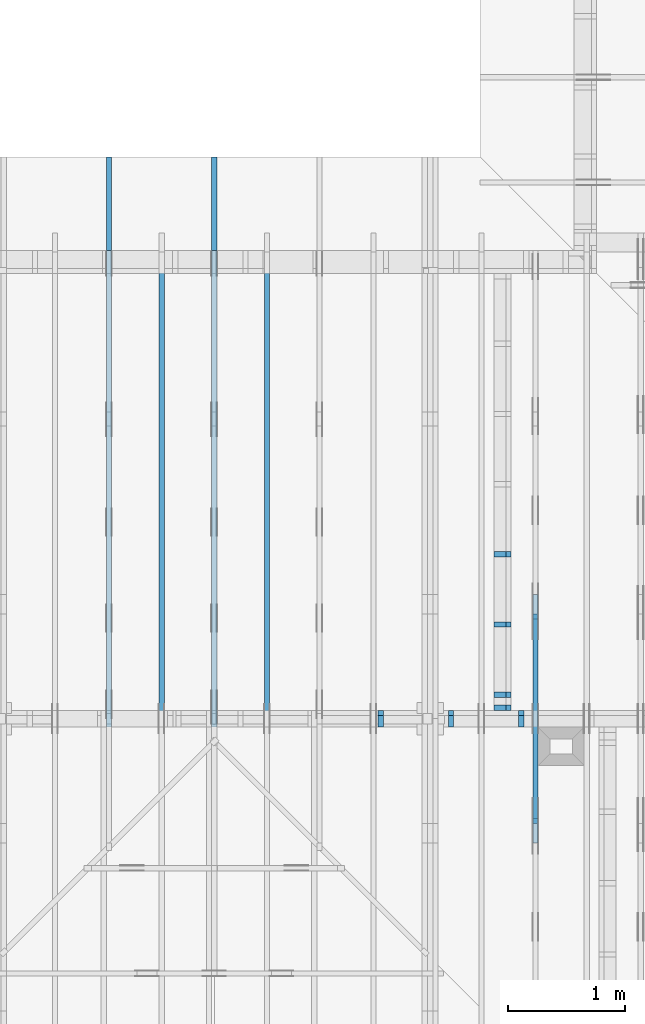
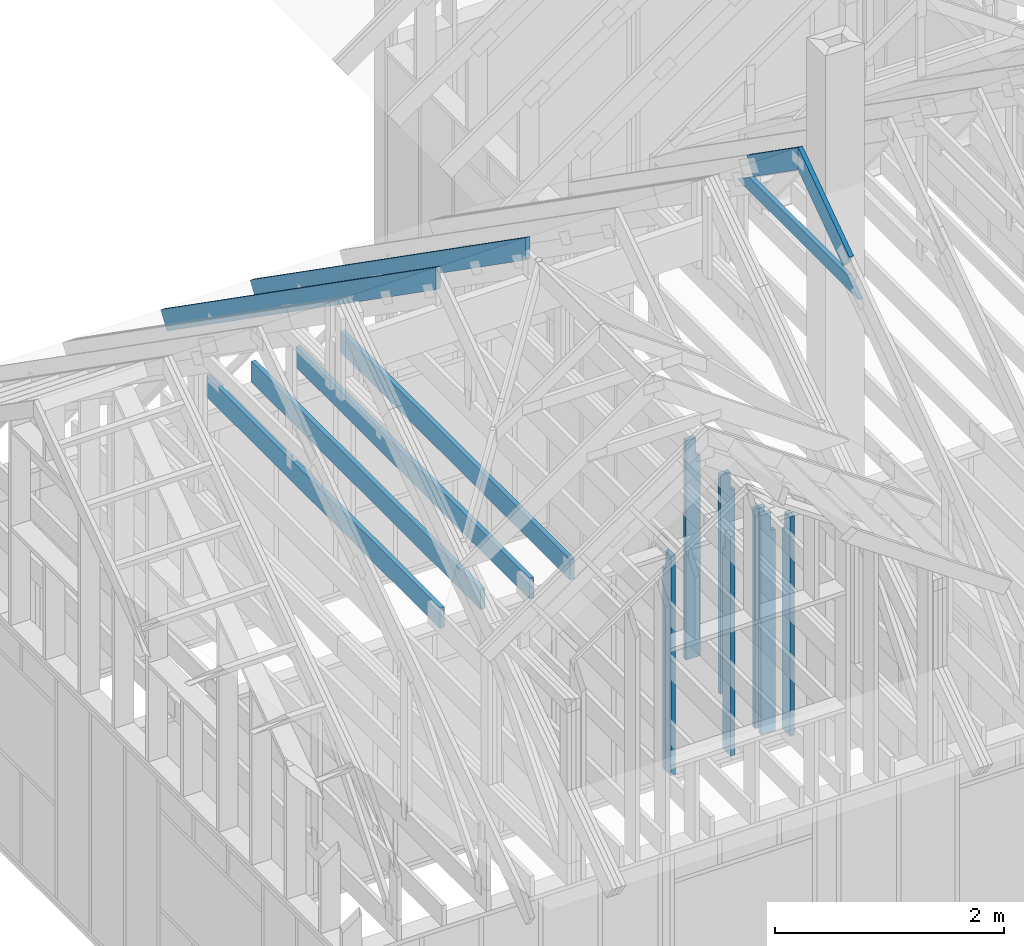
# One storey, part 16 of 70: 16 members, 7 elements without a shape of their own.
"""IFC2X3 building model written with IfcOpenShell, lengths in millimetres."""

from ifc_helpers import new_model, si_unit, frame, origin, origin_with_axes, origin_2d, place, context, project, spatial, faceted_brep, element, aggregate, save


model = new_model("IFC2X3")

# Units and contexts
model_context = context("Model", 3, precision=1e-05, world=origin())
plan_context = context("Plan", 2, precision=1e-05, world=origin_2d())
ifc_project = project(units=[si_unit("LENGTHUNIT", "METRE", prefix="MILLI"), si_unit("AREAUNIT", "SQUARE_METRE"), si_unit("VOLUMEUNIT", "CUBIC_METRE"), si_unit("SOLIDANGLEUNIT", "STERADIAN"), si_unit("PLANEANGLEUNIT", "RADIAN"), si_unit("MASSUNIT", "GRAM"), si_unit("TIMEUNIT", "SECOND"), si_unit("THERMODYNAMICTEMPERATUREUNIT", "DEGREE_CELSIUS"), si_unit("LUMINOUSINTENSITYUNIT", "LUMEN")], contexts=[model_context, plan_context])

# Site, building, storey
site_placement = place(None, origin_with_axes())
site = spatial("IfcSite", under=ifc_project, at=site_placement, CompositionType="ELEMENT")
building_placement = place(site_placement, origin_with_axes())
building = spatial("IfcBuilding", under=site, at=building_placement, Name="Layout 1", CompositionType="ELEMENT")
storey_placement = place(building_placement, origin_with_axes())
storey = spatial("IfcBuildingStorey", under=building, at=storey_placement, Name="Storey 1", CompositionType="ELEMENT", Elevation=0.0)

# Assembly, member
assembly_1_placement = place(storey_placement, frame((3455.0000000000005, 8000.000000000001, 1.3776821480501744e-15), z_axis=(-1.0, 1.836909530733566e-16, 6.123031769111886e-17), x_axis=(-1.836909530733566e-16, -1.0, 0.0)))
assembly_1 = element("IfcElementAssembly", 1, at=assembly_1_placement, inside=storey, Name="MB1", AssemblyPlace="FACTORY", PredefinedType="TRUSS")
member_1_placement = place(assembly_1_placement, frame((4000.0000000000005, 219.99999999999997, -45.0), z_axis=(0.0, 0.0, 1.0), x_axis=(-1.0, 1.2246063538223773e-16, 0.0)))
member_1 = element("IfcMember", 2, at=member_1_placement, Name="B3", context=model_context, shape_type="Brep", body=[
    faceted_brep([(4000.0000000000005, 220.00000000000045, 45.0), (0.0, 220.00000000000045, 45.0), (0.0, 0.0, 45.0), (4000.0000000000005, 0.0, 45.0), (0.0, 220.00000000000045, 0.0), (4000.0000000000005, 220.00000000000045, 4.89842541528951e-13), (4000.0000000000005, 0.0, 4.89842541528951e-13), (0.0, 0.0, 0.0), (0.0, 0.0, 0.0), (2.755364296100349e-15, -3.3742366240998092e-31, 45.0), (2.969670408019265e-14, 220.0, 45.0), (2.69413397840923e-14, 220.0, -1.6496267940043512e-30), (4000.0000000000005, -7.347638122934265e-13, 7.283414641863702e-29), (4000.0000000000005, -7.320084479973261e-13, 45.0), (5.061354936149714e-31, 2.755364296100349e-15, 45.0), (0.0, 0.0, 0.0), (4000.0000000000005, 220.00000000000045, 0.0), (4000.0000000000005, 220.00000000000045, 45.0), (4000.0000000000005, 4.547473508864641e-13, 45.0), (4000.0000000000005, 4.547473508864641e-13, 0.0), (0.0, 220.0, 0.0), (0.0, 220.0, 45.0), (4000.0000000000005, 220.00000000000065, 45.0), (4000.0000000000005, 220.00000000000065, 1.1044052673094165e-29)], [[[0, 1, 2, 3]], [[4, 5, 6, 7]], [[8, 9, 10, 11]], [[12, 13, 14, 15]], [[16, 17, 18, 19]], [[20, 21, 22, 23]]]),
])
aggregate(assembly_1, [member_1])

assembly_2_placement = place(storey_placement, frame((4355.0, 8000.0, 1.3776821480501744e-15), z_axis=(-1.0, 1.836909530733566e-16, 6.123031769111886e-17), x_axis=(-1.836909530733566e-16, -1.0, 0.0)))
assembly_2 = element("IfcElementAssembly", 3, at=assembly_2_placement, inside=storey, Name="MB1", AssemblyPlace="FACTORY", PredefinedType="TRUSS")
member_2_placement = place(assembly_2_placement, frame((4000.0000000000005, 219.99999999999997, -45.0), z_axis=(0.0, 0.0, 1.0), x_axis=(-1.0, 1.2246063538223773e-16, 0.0)))
member_2 = element("IfcMember", 4, at=member_2_placement, Name="B3", context=model_context, shape_type="Brep", body=[
    faceted_brep([(4000.0000000000005, 220.00000000000045, 45.0), (0.0, 220.00000000000045, 45.0), (0.0, 0.0, 45.0), (4000.0000000000005, 0.0, 45.0), (0.0, 220.00000000000045, 0.0), (4000.0000000000005, 220.00000000000045, 4.89842541528951e-13), (4000.0000000000005, 0.0, 4.89842541528951e-13), (0.0, 0.0, 0.0), (0.0, 0.0, 0.0), (2.755364296100349e-15, -3.3742366240998092e-31, 45.0), (2.969670408019265e-14, 220.0, 45.0), (2.69413397840923e-14, 220.0, -1.6496267940043512e-30), (4000.0000000000005, -7.347638122934265e-13, 7.283414641863702e-29), (4000.0000000000005, -7.320084479973261e-13, 45.0), (5.061354936149714e-31, 2.755364296100349e-15, 45.0), (0.0, 0.0, 0.0), (4000.0000000000005, 220.00000000000045, 0.0), (4000.0000000000005, 220.00000000000045, 45.0), (4000.0000000000005, 4.547473508864641e-13, 45.0), (4000.0000000000005, 4.547473508864641e-13, 0.0), (0.0, 220.0, 0.0), (0.0, 220.0, 45.0), (4000.0000000000005, 220.00000000000065, 45.0), (4000.0000000000005, 220.00000000000065, 1.1044052673094165e-29)], [[[0, 1, 2, 3]], [[4, 5, 6, 7]], [[8, 9, 10, 11]], [[12, 13, 14, 15]], [[16, 17, 18, 19]], [[20, 21, 22, 23]]]),
])
aggregate(assembly_2, [member_2])

# Assembly, members
assembly_3_placement = place(storey_placement, frame((-48.55339059327651, 3927.500000000001, -2470.0), z_axis=(0.0, -1.0, 6.123031769111886e-17), x_axis=(1.0, 0.0, 0.0)))
assembly_3 = element("IfcElementAssembly", 5, at=assembly_3_placement, inside=storey, Name="VE8", AssemblyPlace="FACTORY", PredefinedType="NOTDEFINED")
member_3_placement = place(assembly_3_placement, frame((5377.500000001819, 2425.0, -145.0), z_axis=(0.0, 0.0, 1.0), x_axis=(-1.836909530733566e-16, -1.0, 0.0)))
member_3 = element("IfcMember", 6, at=member_3_placement, Name="S42", context=model_context, shape_type="Brep", body=[
    faceted_brep([(0.0, 45.00000000001455, 45.0), (195.00000000186265, 45.00000000001455, 45.00000000000002), (195.00000000186265, 1.4551915228366852e-11, 45.00000000000002), (0.0, 1.4551915228366852e-11, 45.0), (195.00000000186265, 1.3642420526593924e-11, 0.0), (195.00000000186265, 1.3642420526593924e-11, 45.0), (195.00000000186265, 45.00000000001455, 45.0), (195.00000000186265, 45.00000000001455, 0.0), (2.755364296102131e-15, 1.4551915228366852e-11, 45.0), (8.878396065214018e-15, 1.4551915228366852e-11, 145.0), (1.4389124657414716e-14, 45.00000000001455, 145.0), (8.26609288830283e-15, 45.00000000001455, 45.0), (2335.0, 1.4122996852940564e-11, 2.626280839091018e-29), (2335.0, 1.4131875249005776e-11, 145.0), (1.6308810349815745e-30, 1.4560793624432064e-11, 145.0), (5.061354936149714e-31, 1.4554670592662952e-11, 45.0), (195.00000000186265, 1.4518850856813305e-11, 45.0), (195.00000000186265, 1.4516095492517205e-11, 2.193253805685862e-30), (-1.6871183120499046e-31, 45.00000000001455, 45.0), (-5.436270116605248e-31, 45.000000000014545, 145.0), (2335.0, 45.0000000000144, 145.0), (2335.0, 45.00000000001441, -8.67746995743113e-30), (195.00000000186265, 45.00000000001454, -7.888609052210118e-31), (195.00000000186265, 45.00000000001454, 45.0), (2335.0, 45.00000000001455, 2.842170943040401e-14), (2335.0, 45.00000000001455, 145.0), (2335.0, 0.0, 145.0), (2335.0, 0.0, 2.842170943040401e-14), (2335.0, 45.00000000001455, 145.0), (0.0, 45.00000000001455, 145.0), (0.0, 1.4551915228366852e-11, 145.0), (2335.0, 1.4551915228366852e-11, 145.0), (195.00000000186265, 45.00000000001455, 2.3879823899764457e-14), (2335.0, 45.00000000001455, 2.859455836175251e-13), (2335.0, 0.0, 2.859455836175251e-13), (195.00000000186265, 0.0, 2.3879823899764457e-14)], [[[0, 1, 2, 3]], [[4, 5, 6, 7]], [[8, 9, 10, 11]], [[12, 13, 14, 15, 16, 17]], [[18, 19, 20, 21, 22, 23]], [[24, 25, 26, 27]], [[28, 29, 30, 31]], [[32, 33, 34, 35]]]),
])
member_4_placement = place(assembly_3_placement, frame((5977.5000000018335, 2425.0, -145.0), z_axis=(0.0, 0.0, 1.0), x_axis=(-1.836909530733566e-16, -1.0, 0.0)))
member_4 = element("IfcMember", 7, at=member_4_placement, Name="S42", context=model_context, shape_type="Brep", body=[
    faceted_brep([(0.0, 45.00000000001455, 45.0), (195.00000000186265, 45.00000000001455, 45.00000000000002), (195.00000000186265, 0.0, 45.00000000000002), (0.0, 0.0, 45.0), (195.00000000186265, 0.0, 0.0), (195.00000000186265, -3.3742366240998092e-31, 45.0), (195.00000000186265, 45.00000000001364, 45.0), (195.00000000186265, 45.00000000001364, 0.0), (2.755364296100349e-15, -3.3742366240998092e-31, 45.0), (8.878396065212235e-15, -1.0872540233210496e-30, 145.0), (1.4389124657414716e-14, 45.00000000001455, 145.0), (8.26609288830283e-15, 45.00000000001455, 45.0), (2335.0, -4.2891837542628763e-13, 2.626280839091018e-29), (2335.0, -4.200399793610754e-13, 145.0), (1.6308810349815745e-30, 8.878396065212235e-15, 145.0), (5.061354936149714e-31, 2.755364296100349e-15, 45.0), (195.00000000186265, -3.306437155354634e-14, 45.0), (195.00000000186265, -3.5819735849646686e-14, 2.193253805685826e-30), (-1.6871183120499046e-31, 45.00000000001364, 45.0), (-5.436270116605248e-31, 45.000000000013635, 145.0), (2335.0, 45.00000000001349, 145.0), (2335.0, 45.0000000000135, -8.67746995743113e-30), (195.00000000186265, 45.00000000001363, -7.888609052210118e-31), (195.00000000186265, 45.00000000001363, 45.0), (2335.0, 45.0, 2.842170943040401e-14), (2335.0, 45.0, 145.0), (2335.0, 0.0, 145.0), (2335.0, 0.0, 0.0), (2335.0, 45.0, 145.0), (0.0, 45.0, 145.0), (0.0, 0.0, 145.0), (2335.0, 0.0, 145.0), (195.00000000186265, 45.00000000001364, 2.3879823899764457e-14), (2335.0, 45.00000000001364, 2.859455836175251e-13), (2335.0, 0.0, 2.859455836175251e-13), (195.00000000186265, 0.0, 2.3879823899764457e-14)], [[[0, 1, 2, 3]], [[4, 5, 6, 7]], [[8, 9, 10, 11]], [[12, 13, 14, 15, 16, 17]], [[18, 19, 20, 21, 22, 23]], [[24, 25, 26, 27]], [[28, 29, 30, 31]], [[32, 33, 34, 35]]]),
])
member_5_placement = place(assembly_3_placement, frame((6577.500000001819, 2425.0, -145.0), z_axis=(0.0, 0.0, 1.0), x_axis=(-1.836909530733566e-16, -1.0, 0.0)))
member_5 = element("IfcMember", 8, at=member_5_placement, Name="S42", context=model_context, shape_type="Brep", body=[
    faceted_brep([(0.0, 45.00000000001455, 45.0), (195.00000000186265, 45.00000000001455, 45.00000000000002), (195.00000000186265, 2.9103830456733704e-11, 45.00000000000002), (0.0, 2.9103830456733704e-11, 45.0), (195.00000000186265, 2.637534635141492e-11, 0.0), (195.00000000186265, 2.637534635141492e-11, 45.0), (195.00000000186265, 45.00000000001364, 45.0), (195.00000000186265, 45.00000000001364, 0.0), (2.755364296103913e-15, 2.9103830456733704e-11, 45.0), (8.878396065215799e-15, 2.9103830456733704e-11, 145.0), (1.4389124657414716e-14, 45.00000000001455, 145.0), (8.26609288830283e-15, 45.00000000001455, 45.0), (2335.0, 2.8674912081307416e-11, 2.626280839091018e-29), (2335.0, 2.8683790477372628e-11, 145.0), (1.6308810349815745e-30, 2.9112708852798916e-11, 145.0), (5.061354936149714e-31, 2.9106585821029804e-11, 45.0), (195.00000000186265, 2.9070766085180157e-11, 45.0), (195.00000000186265, 2.9068010720884057e-11, 2.1932538056856825e-30), (-1.6871183120499046e-31, 45.00000000001364, 45.0), (-5.436270116605248e-31, 45.000000000013635, 145.0), (2335.0, 45.00000000001349, 145.0), (2335.0, 45.0000000000135, -8.67746995743113e-30), (195.00000000186265, 45.00000000001363, -7.888609052210118e-31), (195.00000000186265, 45.00000000001363, 45.0), (2335.0, 45.0, 2.842170943040401e-14), (2335.0, 45.0, 145.0), (2335.0, 0.0, 145.0), (2335.0, 0.0, 0.0), (2335.0, 45.0, 145.0), (0.0, 45.0, 145.0), (0.0, 2.9103830456733704e-11, 145.0), (2335.0, 2.9103830456733704e-11, 145.0), (195.00000000186265, 45.00000000001364, 2.3879823899764457e-14), (2335.0, 45.00000000001364, 2.859455836175251e-13), (2335.0, 0.0, 2.859455836175251e-13), (195.00000000186265, 0.0, 2.3879823899764457e-14)], [[[0, 1, 2, 3]], [[4, 5, 6, 7]], [[8, 9, 10, 11]], [[12, 13, 14, 15, 16, 17]], [[18, 19, 20, 21, 22, 23]], [[24, 25, 26, 27]], [[28, 29, 30, 31]], [[32, 33, 34, 35]]]),
])
aggregate(assembly_3, [member_3, member_4, member_5])

assembly_4_placement = place(storey_placement, frame((6650.000000000001, 8000.0, -9.081170196248781e-13), z_axis=(-1.0, 1.836909530733566e-16, 6.123031769111886e-17), x_axis=(-1.836909530733566e-16, -1.0, 0.0)))
assembly_4 = element("IfcElementAssembly", 9, at=assembly_4_placement, inside=storey, Name="T12", AssemblyPlace="FACTORY", PredefinedType="TRUSS")
member_6_placement = place(assembly_4_placement, frame((3217.690358731264, 3015.0000000002183, -45.00000000000001), z_axis=(0.0, 0.0, 1.0), x_axis=(0.8191520442889918, 0.5735764363510462, 0.0)))
member_6 = element("IfcMember", 10, at=member_6_placement, Name="T18", context=model_context, shape_type="Brep", body=[
    faceted_brep([(1091.564200553914, 194.99999999865213, 45.0), (0.0, 194.99999999865213, 45.0), (1.6370904631912708e-10, 7.557900971733034e-10, 45.0), (955.0237306039635, 7.557900971733034e-10, 45.0), (0.0, 194.99999999865213, 0.0), (1091.564200553914, 194.99999999865213, 1.3367364556033665e-13), (955.0237306039635, 7.557900971733034e-10, 1.169528128548764e-13), (1.6370904631912708e-10, 7.557900971733034e-10, 2.004791383006049e-26), (1.6370904631912732e-10, 7.557900971733033e-10, -1.4349296274686127e-41), (1.6371180168342342e-10, 7.557900971733033e-10, 45.0), (6.660321774678196e-14, 194.99999999996407, 45.0), (6.384785345068161e-14, 194.99999999996407, -3.909424350681179e-30), (955.0237306039635, -1.5956987698560245e-13, 9.770514261762543e-30), (955.0237306039635, -1.568145126895021e-13, 45.0), (1.6370904631912708e-10, 7.557928525375995e-10, 45.0), (1.6370904631912708e-10, 7.557900971733034e-10, 0.0), (1091.564200553914, 194.99999999865213, 0.0), (1091.564200553914, 194.99999999865213, 45.0), (955.0237306039635, -5.684341886080802e-14, 45.0), (955.0237306039635, -5.684341886080802e-14, -6.310887241768095e-30), (0.0, 194.99999999996407, 0.0), (0.0, 194.99999999996407, 45.0), (1091.564200553914, 194.99999999865202, 45.0), (1091.564200553914, 194.99999999865202, -6.310887241768095e-30)], [[[0, 1, 2, 3]], [[4, 5, 6, 7]], [[8, 9, 10, 11]], [[12, 13, 14, 15]], [[16, 17, 18, 19]], [[20, 21, 22, 23]]]),
])
member_7_placement = place(assembly_4_placement, frame((3888.1525949105694, 3641.0955042035366, -45.00000000000001), z_axis=(0.0, 0.0, 1.0), x_axis=(0.8191520442889916, -0.5735764363510465, 0.0)))
member_7 = element("IfcMember", 11, at=member_7_placement, Name="T18", context=model_context, shape_type="Brep", body=[
    faceted_brep([(1091.5642005560503, 194.99999999996362, 45.0), (0.0, 194.99999999996362, 45.0), (136.54046995208614, 0.0, 45.0), (1091.5642005561149, 0.0, 45.0), (0.0, 194.99999999996362, 0.0), (1091.5642005560503, 194.99999999996362, 1.336736455605983e-13), (1091.5642005561149, 0.0, 1.336736455606062e-13), (136.54046995208614, 0.0, 1.6720832705721806e-14), (136.54046995208614, -2.842170943040401e-14, 3.0619884913871384e-31), (136.54046995208614, -2.842170943040401e-14, 45.0), (1.4210854715202004e-14, 195.00000000170263, 45.0), (1.4210854715202004e-14, 195.00000000170263, -5.932810329456638e-31), (1091.5642005561149, 2.0525182992035534e-09, 1.2934457505131873e-29), (1091.5642005561149, 2.0525210545678495e-09, 45.0), (136.54046995208614, -2.3668346958569874e-14, 45.0), (136.54046995208614, -2.6423711254670222e-14, 1.6179322347011683e-30), (1091.5642005561149, 194.99999999996362, 3.950615413346827e-27), (1091.5642005561149, 194.99999999996362, 45.0), (1091.5642005561149, 2.052729541901499e-09, 45.0), (1091.5642005561149, 2.052729541901499e-09, 0.0), (0.0, 195.00000000170257, 0.0), (0.0, 195.00000000170257, 45.0), (1091.5642005560503, 194.9999999999637, 45.0), (1091.5642005560503, 194.9999999999637, 6.310887241768095e-30)], [[[0, 1, 2, 3]], [[4, 5, 6, 7]], [[8, 9, 10, 11]], [[12, 13, 14, 15]], [[16, 17, 18, 19]], [[20, 21, 22, 23]]]),
])
member_8_placement = place(assembly_4_placement, frame((5060.798502586593, 2964.999999998785, -45.0), z_axis=(0.0, 0.0, 1.0), x_axis=(-1.0, 1.2246063538223773e-16, 0.0)))
member_8 = element("IfcMember", 12, at=member_8_placement, Name="C1", context=model_context, shape_type="Brep", body=[
    faceted_brep([(2121.597005175296, 145.00000000000728, 45.0), (0.0, 145.00000000000728, 45.0), (207.08146097743884, 0.0, 45.0), (1914.5155441979737, 0.0, 45.0), (0.0, 145.00000000000728, 0.0), (2121.597005175296, 145.00000000000728, 2.5981211727881944e-13), (1914.5155441979737, 0.0, 2.3445278999165447e-13), (207.08146097743884, 0.0, 2.5359327287179227e-14), (207.08146097743878, -7.105427357601002e-14, 3.1554436208840472e-30), (207.08146097743878, -7.105427357601002e-14, 45.0), (1.4210854715202004e-14, 145.00000000000728, 45.0), (1.4210854715202004e-14, 145.00000000000728, 0.0), (1914.5155441979737, 7.26803319922997e-12, 4.8521444511629875e-31), (1914.5155441979737, 7.27078856352607e-12, 45.0), (207.08146097743884, 1.898228698049977e-15, 45.0), (207.08146097743884, -8.571355980503717e-16, 5.248268497299439e-32), (2121.597005175296, 145.00000000000728, 0.0), (2121.597005175296, 145.00000000000728, 45.0), (1914.515544197974, 7.389644451905042e-12, 45.0), (1914.515544197974, 7.389644451905042e-12, 1.262177448353619e-29), (0.0, 145.00000000000728, 0.0), (-1.6871183120499046e-31, 145.00000000000728, 45.0), (2121.597005175296, 145.00000000000713, 45.0), (2121.597005175296, 145.00000000000713, -7.888609052210118e-30)], [[[0, 1, 2, 3]], [[4, 5, 6, 7]], [[8, 9, 10, 11]], [[12, 13, 14, 15]], [[16, 17, 18, 19]], [[20, 21, 22, 23]]]),
])
aggregate(assembly_4, [member_6, member_7, member_8])

assembly_5_placement = place(storey_placement, frame((3905.0000000000005, 8000.000000000001, -4.5336966873841394e-13), z_axis=(-1.0, 1.836909530733566e-16, 6.123031769111886e-17), x_axis=(-1.836909530733566e-16, -1.0, 0.0)))
assembly_5 = element("IfcElementAssembly", 13, at=assembly_5_placement, inside=storey, Name="T1", AssemblyPlace="FACTORY", PredefinedType="TRUSS")
member_9_placement = place(assembly_5_placement, frame((-688.1525949109839, 280.09932079477335, -45.0), z_axis=(0.0, 0.0, 1.0), x_axis=(0.8191520442889916, 0.5735764363510464, 0.0)))
member_9 = element("IfcMember", 14, at=member_9_placement, Name="T7", context=model_context, shape_type="Brep", body=[
    faceted_brep([(5859.718026055497, 195.00000000170348, 45.0), (0.0, 195.00000000170348, 45.0), (3.9250380723387934e-10, 4.743014869745821e-10, 45.0), (5723.177556103411, 4.743014869745821e-10, 45.0), (0.0, 195.00000000170348, 0.0), (5859.718026055497, 195.00000000170348, 7.17584792631508e-13), (5723.177556103411, 4.743014869745821e-10, 7.008639599257862e-13), (3.9250380723387934e-10, 4.743014869745821e-10, 4.806626562380822e-26), (3.9250380723387955e-10, 4.743014869745821e-10, -1.4349296274686127e-41), (3.9250656259817565e-10, 4.743014869745821e-10, 45.0), (7.10441081636244e-14, 195.00000000097975, 45.0), (6.828874386752406e-14, 195.00000000097975, -4.1813414817381065e-30), (5723.177556103411, -4.570871924930312e-12, 2.7987594008890623e-28), (5723.177556103411, -4.5681165606342115e-12, 45.0), (3.925038072338793e-10, 4.743042423388779e-10, 45.0), (3.925038072338793e-10, 4.743014869745818e-10, 1.7219155529623352e-41), (5859.718026055498, 195.00000000170212, 5.048709793414476e-29), (5859.718026055498, 195.00000000170212, 45.0), (5723.177556103412, -9.094947017729282e-13, 45.0), (5723.177556103412, -9.094947017729282e-13, 5.048709793414476e-29), (0.0, 195.00000000097975, 0.0), (0.0, 195.00000000097975, 45.0), (5859.718026055498, 195.00000000170542, 45.0), (5859.718026055498, 195.00000000170542, 1.199068575935938e-28)], [[[0, 1, 2, 3]], [[4, 5, 6, 7]], [[8, 9, 10, 11]], [[12, 13, 14, 15]], [[16, 17, 18, 19]], [[20, 21, 22, 23]]]),
])
member_10_placement = place(assembly_5_placement, frame((4072.5, 220.0, -45.0), z_axis=(0.0, 0.0, 1.0), x_axis=(-1.0, 1.2246063538223773e-16, 0.0)))
member_10 = element("IfcMember", 15, at=member_10_placement, Name="B2", context=model_context, shape_type="Brep", body=[
    faceted_brep([(4072.5, 220.0000000000005, 45.0), (0.0, 220.0000000000005, 45.0), (0.0, 0.0, 45.0), (4072.5000000000005, 0.0, 45.0), (0.0, 220.0000000000005, 0.0), (4072.5, 220.0000000000005, 4.987209375941631e-13), (4072.5000000000005, 0.0, 4.987209375941632e-13), (0.0, 0.0, 0.0), (0.0, 0.0, 0.0), (2.755364296100349e-15, -3.3742366240998092e-31, 45.0), (2.969670408019265e-14, 220.0, 45.0), (2.69413397840923e-14, 220.0, -1.6496267940043512e-30), (4072.5000000000005, -7.480814063912448e-13, 7.713012753162442e-29), (4072.5000000000005, -7.453260420951445e-13, 45.0), (5.061354936149714e-31, 2.755364296100349e-15, 45.0), (0.0, 0.0, 0.0), (4072.5000000000005, 220.0000000000005, 5.048709793414476e-29), (4072.5000000000005, 220.0000000000005, 45.0), (4072.5000000000005, 5.115907697472721e-13, 45.0), (4072.5000000000005, 5.115907697472721e-13, 0.0), (0.0, 220.0, 0.0), (0.0, 220.0, 45.0), (4072.5, 220.00000000000065, 45.0), (4072.5, 220.00000000000065, 7.888609052210118e-30)], [[[0, 1, 2, 3]], [[4, 5, 6, 7]], [[8, 9, 10, 11]], [[12, 13, 14, 15]], [[16, 17, 18, 19]], [[20, 21, 22, 23]]]),
])
aggregate(assembly_5, [member_9, member_10])

assembly_6_placement = place(storey_placement, frame((3005.0000000000005, 8000.0, 1.3776821480501744e-15), z_axis=(-1.0, 1.836909530733566e-16, 6.123031769111886e-17), x_axis=(-1.836909530733566e-16, -1.0, 0.0)))
assembly_6 = element("IfcElementAssembly", 16, at=assembly_6_placement, inside=storey, Name="T1", AssemblyPlace="FACTORY", PredefinedType="TRUSS")
member_11_placement = place(assembly_6_placement, frame((-688.1525949109839, 280.09932079477335, -45.0), z_axis=(0.0, 0.0, 1.0), x_axis=(0.8191520442889916, 0.5735764363510464, 0.0)))
member_11 = element("IfcMember", 17, at=member_11_placement, Name="T7", context=model_context, shape_type="Brep", body=[
    faceted_brep([(5859.718026055497, 195.00000000170348, 45.0), (0.0, 195.00000000170348, 45.0), (3.9250380723387934e-10, 4.743014869745821e-10, 45.0), (5723.177556103411, 4.743014869745821e-10, 45.0), (0.0, 195.00000000170348, 0.0), (5859.718026055497, 195.00000000170348, 7.17584792631508e-13), (5723.177556103411, 4.743014869745821e-10, 7.008639599257862e-13), (3.9250380723387934e-10, 4.743014869745821e-10, 4.806626562380822e-26), (3.9250380723387955e-10, 4.743014869745821e-10, -1.4349296274686127e-41), (3.9250656259817565e-10, 4.743014869745821e-10, 45.0), (7.10441081636244e-14, 195.00000000097975, 45.0), (6.828874386752406e-14, 195.00000000097975, -4.1813414817381065e-30), (5723.177556103411, -4.570871924930312e-12, 2.7987594008890623e-28), (5723.177556103411, -4.5681165606342115e-12, 45.0), (3.925038072338793e-10, 4.743042423388779e-10, 45.0), (3.925038072338793e-10, 4.743014869745818e-10, 1.7219155529623352e-41), (5859.718026055498, 195.00000000170212, 5.048709793414476e-29), (5859.718026055498, 195.00000000170212, 45.0), (5723.177556103412, -9.094947017729282e-13, 45.0), (5723.177556103412, -9.094947017729282e-13, 5.048709793414476e-29), (0.0, 195.00000000097975, 0.0), (0.0, 195.00000000097975, 45.0), (5859.718026055498, 195.00000000170542, 45.0), (5859.718026055498, 195.00000000170542, 1.199068575935938e-28)], [[[0, 1, 2, 3]], [[4, 5, 6, 7]], [[8, 9, 10, 11]], [[12, 13, 14, 15]], [[16, 17, 18, 19]], [[20, 21, 22, 23]]]),
])
member_12_placement = place(assembly_6_placement, frame((4072.5, 220.0, -45.0), z_axis=(0.0, 0.0, 1.0), x_axis=(-1.0, 1.2246063538223773e-16, 0.0)))
member_12 = element("IfcMember", 18, at=member_12_placement, Name="B2", context=model_context, shape_type="Brep", body=[
    faceted_brep([(4072.5, 220.0000000000005, 45.0), (0.0, 220.0000000000005, 45.0), (0.0, 0.0, 45.0), (4072.5000000000005, 0.0, 45.0), (0.0, 220.0000000000005, 0.0), (4072.5, 220.0000000000005, 4.987209375941631e-13), (4072.5000000000005, 0.0, 4.987209375941632e-13), (0.0, 0.0, 0.0), (0.0, 0.0, 0.0), (2.755364296100349e-15, -3.3742366240998092e-31, 45.0), (2.969670408019265e-14, 220.0, 45.0), (2.69413397840923e-14, 220.0, -1.6496267940043512e-30), (4072.5000000000005, -7.480814063912448e-13, 7.713012753162442e-29), (4072.5000000000005, -7.453260420951445e-13, 45.0), (5.061354936149714e-31, 2.755364296100349e-15, 45.0), (0.0, 0.0, 0.0), (4072.5000000000005, 220.0000000000005, 5.048709793414476e-29), (4072.5000000000005, 220.0000000000005, 45.0), (4072.5000000000005, 5.115907697472721e-13, 45.0), (4072.5000000000005, 5.115907697472721e-13, 0.0), (0.0, 220.0, 0.0), (0.0, 220.0, 45.0), (4072.5, 220.00000000000065, 45.0), (4072.5, 220.00000000000065, 7.888609052210118e-30)], [[[0, 1, 2, 3]], [[4, 5, 6, 7]], [[8, 9, 10, 11]], [[12, 13, 14, 15]], [[16, 17, 18, 19]], [[20, 21, 22, 23]]]),
])
aggregate(assembly_6, [member_11, member_12])

assembly_7_placement = place(storey_placement, frame((6320.15185546875, 7805.0, -2470.0), z_axis=(-1.0, 1.836909530733566e-16, 6.123031769111886e-17), x_axis=(-1.836909530733566e-16, -1.0, 0.0)))
assembly_7 = element("IfcElementAssembly", 19, at=assembly_7_placement, inside=storey, Name="VE7", AssemblyPlace="FACTORY", PredefinedType="NOTDEFINED")
member_13_placement = place(assembly_7_placement, frame((3687.5, 2425.0000000000005, -145.0), z_axis=(0.0, 0.0, 1.0), x_axis=(-1.836909530733566e-16, -1.0, 0.0)))
member_13 = element("IfcMember", 20, at=member_13_placement, Name="S42", context=model_context, shape_type="Brep", body=[
    faceted_brep([(0.0, 45.0, 45.0), (195.00000000186265, 45.0, 45.00000000000002), (195.0000000018631, 0.0, 45.00000000000002), (4.547473508864641e-13, 0.0, 45.0), (195.0000000018631, 0.0, 0.0), (195.0000000018631, 0.0, 45.0), (195.00000000186267, 44.99999999999999, 45.0), (195.00000000186267, 44.99999999999999, -1.5777218104420236e-30), (4.575027151825645e-13, 2.658238250588413e-29, 45.0), (4.636257469516764e-13, 8.565434363007109e-29, 145.0), (2.948815779231506e-14, 45.0, 145.0), (2.3365126023203175e-14, 45.0, 45.0), (2335.0, -4.2891837542628763e-13, 2.626280839091018e-29), (2335.0, -4.200399793610754e-13, 145.0), (4.547473508864641e-13, 8.878396065212152e-15, 145.0), (4.547473508864641e-13, 2.7553642961002652e-15, 45.0), (195.0000000018631, -3.306437155354642e-14, 45.0), (195.0000000018631, -3.581973584964677e-14, 2.193253805685831e-30), (-1.6871183120499046e-31, 45.0, 45.0), (-5.436270116605248e-31, 44.99999999999999, 145.0), (2335.0, 44.99999999999985, 145.0), (2335.0, 44.99999999999986, -8.67746995743113e-30), (195.00000000186265, 44.999999999999986, -7.888609052210118e-31), (195.00000000186265, 44.999999999999986, 45.0), (2335.0, 45.000000000000455, 2.842170943040401e-14), (2335.0, 45.000000000000455, 145.0), (2335.0, 4.547473508864641e-13, 145.0), (2335.0, 4.547473508864641e-13, 0.0), (2335.0, 45.000000000000455, 145.0), (0.0, 45.000000000000455, 145.0), (4.547473508864641e-13, 0.0, 145.0), (2335.0, 0.0, 145.0), (195.00000000186265, 45.0, 2.3879823899764457e-14), (2335.0, 45.0, 2.859455836175251e-13), (2335.0, 4.547473508864641e-13, 2.859455836175251e-13), (195.0000000018631, 4.547473508864641e-13, 2.3879823899764514e-14)], [[[0, 1, 2, 3]], [[4, 5, 6, 7]], [[8, 9, 10, 11]], [[12, 13, 14, 15, 16, 17]], [[18, 19, 20, 21, 22, 23]], [[24, 25, 26, 27]], [[28, 29, 30, 31]], [[32, 33, 34, 35]]]),
])
member_14_placement = place(assembly_7_placement, frame((2377.500000001819, 2425.0, -145.0), z_axis=(0.0, 0.0, 1.0), x_axis=(-1.836909530733566e-16, -1.0, 0.0)))
member_14 = element("IfcMember", 21, at=member_14_placement, Name="T18", context=model_context, shape_type="Brep", body=[
    faceted_brep([(0.0, 45.00000000001455, 45.0), (195.00000000186265, 45.00000000001455, 45.00000000000002), (195.00000000186265, 0.0, 45.00000000000002), (0.0, 0.0, 45.0), (195.00000000186265, 0.0, 0.0), (195.00000000186265, -3.3742366240998092e-31, 45.0), (195.00000000186265, 45.00000000001319, 45.0), (195.00000000186265, 45.00000000001319, 0.0), (2.755364296100349e-15, -3.3742366240998092e-31, 45.0), (8.878396065212235e-15, -1.0872540233210496e-30, 145.0), (1.4389124657414716e-14, 45.00000000001455, 145.0), (8.26609288830283e-15, 45.00000000001455, 45.0), (2335.0, -4.2891837542628763e-13, 2.626280839091018e-29), (2335.0, -4.200399793610754e-13, 145.0), (1.6308810349815745e-30, 8.878396065212235e-15, 145.0), (5.061354936149714e-31, 2.755364296100349e-15, 45.0), (195.00000000186265, -3.306437155354634e-14, 45.0), (195.00000000186265, -3.5819735849646686e-14, 2.193253805685826e-30), (-1.6871183120499046e-31, 45.00000000001319, 45.0), (-5.436270116605248e-31, 45.00000000001318, 145.0), (2335.0, 45.00000000001304, 145.0), (2335.0, 45.000000000013046, -8.67746995743113e-30), (195.00000000186265, 45.00000000001317, -7.888609052210118e-31), (195.00000000186265, 45.00000000001317, 45.0), (2335.0, 45.000000000000455, 2.842170943040401e-14), (2335.0, 45.000000000000455, 145.0), (2335.0, 4.547473508864641e-13, 145.0), (2335.0, 4.547473508864641e-13, 0.0), (2335.0, 45.000000000000455, 145.0), (0.0, 45.000000000000455, 145.0), (0.0, 0.0, 145.0), (2335.0, 0.0, 145.0), (195.00000000186265, 45.00000000001319, 2.3879823899764457e-14), (2335.0, 45.00000000001319, 2.859455836175251e-13), (2335.0, 4.547473508864641e-13, 2.859455836175251e-13), (195.00000000186265, 4.547473508864641e-13, 2.3879823899764457e-14)], [[[0, 1, 2, 3]], [[4, 5, 6, 7]], [[8, 9, 10, 11]], [[12, 13, 14, 15, 16, 17]], [[18, 19, 20, 21, 22, 23]], [[24, 25, 26, 27]], [[28, 29, 30, 31]], [[32, 33, 34, 35]]]),
])
member_15_placement = place(assembly_7_placement, frame((2977.500000001819, 2425.0, -145.0), z_axis=(0.0, 0.0, 1.0), x_axis=(-1.836909530733566e-16, -1.0, 0.0)))
member_15 = element("IfcMember", 22, at=member_15_placement, Name="S42", context=model_context, shape_type="Brep", body=[
    faceted_brep([(0.0, 45.00000000001455, 45.0), (195.00000000186265, 45.00000000001455, 45.00000000000002), (195.00000000186265, 0.0, 45.00000000000002), (0.0, 0.0, 45.0), (195.00000000186265, 0.0, 0.0), (195.00000000186265, -3.3742366240998092e-31, 45.0), (195.00000000186265, 45.00000000001455, 45.0), (195.00000000186265, 45.00000000001455, 0.0), (2.755364296100349e-15, -3.3742366240998092e-31, 45.0), (8.878396065212235e-15, -1.0872540233210496e-30, 145.0), (1.4389124657414716e-14, 45.00000000001455, 145.0), (8.26609288830283e-15, 45.00000000001455, 45.0), (2335.0, -4.2891837542628763e-13, 2.626280839091018e-29), (2335.0, -4.200399793610754e-13, 145.0), (1.6308810349815745e-30, 8.878396065212235e-15, 145.0), (5.061354936149714e-31, 2.755364296100349e-15, 45.0), (195.00000000186265, -3.306437155354634e-14, 45.0), (195.00000000186265, -3.5819735849646686e-14, 2.193253805685826e-30), (-1.6871183120499046e-31, 45.00000000001455, 45.0), (-5.436270116605248e-31, 45.000000000014545, 145.0), (2335.0, 45.0000000000144, 145.0), (2335.0, 45.00000000001441, -8.67746995743113e-30), (195.00000000186265, 45.00000000001454, -7.888609052210118e-31), (195.00000000186265, 45.00000000001454, 45.0), (2335.0, 45.00000000001501, 2.842170943040401e-14), (2335.0, 45.00000000001501, 145.0), (2335.0, 4.547473508864641e-13, 145.0), (2335.0, 4.547473508864641e-13, 2.842170943040401e-14), (2335.0, 45.00000000001501, 145.0), (0.0, 45.00000000001501, 145.0), (0.0, 0.0, 145.0), (2335.0, 0.0, 145.0), (195.00000000186265, 45.00000000001455, 2.3879823899764457e-14), (2335.0, 45.00000000001455, 2.859455836175251e-13), (2335.0, 4.547473508864641e-13, 2.859455836175251e-13), (195.00000000186265, 4.547473508864641e-13, 2.3879823899764457e-14)], [[[0, 1, 2, 3]], [[4, 5, 6, 7]], [[8, 9, 10, 11]], [[12, 13, 14, 15, 16, 17]], [[18, 19, 20, 21, 22, 23]], [[24, 25, 26, 27]], [[28, 29, 30, 31]], [[32, 33, 34, 35]]]),
])
member_16_placement = place(assembly_7_placement, frame((3577.500000001819, 2425.0, -145.0), z_axis=(0.0, 0.0, 1.0), x_axis=(-1.836909530733566e-16, -1.0, 0.0)))
member_16 = element("IfcMember", 23, at=member_16_placement, Name="S42", context=model_context, shape_type="Brep", body=[
    faceted_brep([(0.0, 45.00000000001455, 45.0), (195.00000000186265, 45.00000000001455, 45.00000000000002), (195.00000000186265, 0.0, 45.00000000000002), (0.0, 0.0, 45.0), (195.00000000186265, 1.3642420526593924e-12, 0.0), (195.00000000186265, 1.3642420526593924e-12, 45.0), (195.00000000186265, 45.00000000001455, 45.0), (195.00000000186265, 45.00000000001455, 0.0), (2.755364296100349e-15, -3.3742366240998092e-31, 45.0), (8.878396065212235e-15, -1.0872540233210496e-30, 145.0), (1.4389124657414716e-14, 45.00000000001455, 145.0), (8.26609288830283e-15, 45.00000000001455, 45.0), (2335.0, -4.2891837542628763e-13, 2.626280839091018e-29), (2335.0, -4.200399793610754e-13, 145.0), (1.6308810349815745e-30, 8.878396065212235e-15, 145.0), (5.061354936149714e-31, 2.755364296100349e-15, 45.0), (195.00000000186265, -3.306437155354634e-14, 45.0), (195.00000000186265, -3.5819735849646686e-14, 2.193253805685826e-30), (-1.6871183120499046e-31, 45.00000000001455, 45.0), (-5.436270116605248e-31, 45.000000000014545, 145.0), (2335.0, 45.0000000000144, 145.0), (2335.0, 45.00000000001441, -8.67746995743113e-30), (195.00000000186265, 45.00000000001454, -7.888609052210118e-31), (195.00000000186265, 45.00000000001454, 45.0), (2335.0, 45.00000000001501, 2.842170943040401e-14), (2335.0, 45.00000000001501, 145.0), (2335.0, 1.5006662579253316e-11, 145.0), (2335.0, 1.5006662579253316e-11, 0.0), (2335.0, 45.00000000001501, 145.0), (0.0, 45.00000000001501, 145.0), (0.0, 0.0, 145.0), (2335.0, 0.0, 145.0), (195.00000000186265, 45.00000000001455, 2.3879823899764457e-14), (2335.0, 45.00000000001455, 2.859455836175251e-13), (2335.0, 1.5006662579253316e-11, 2.859455836175251e-13), (195.00000000186265, 1.5006662579253316e-11, 2.3879823899764457e-14)], [[[0, 1, 2, 3]], [[4, 5, 6, 7]], [[8, 9, 10, 11]], [[12, 13, 14, 15, 16, 17]], [[18, 19, 20, 21, 22, 23]], [[24, 25, 26, 27]], [[28, 29, 30, 31]], [[32, 33, 34, 35]]]),
])
aggregate(assembly_7, [member_13, member_14, member_15, member_16])

save(model, "model.ifc")
